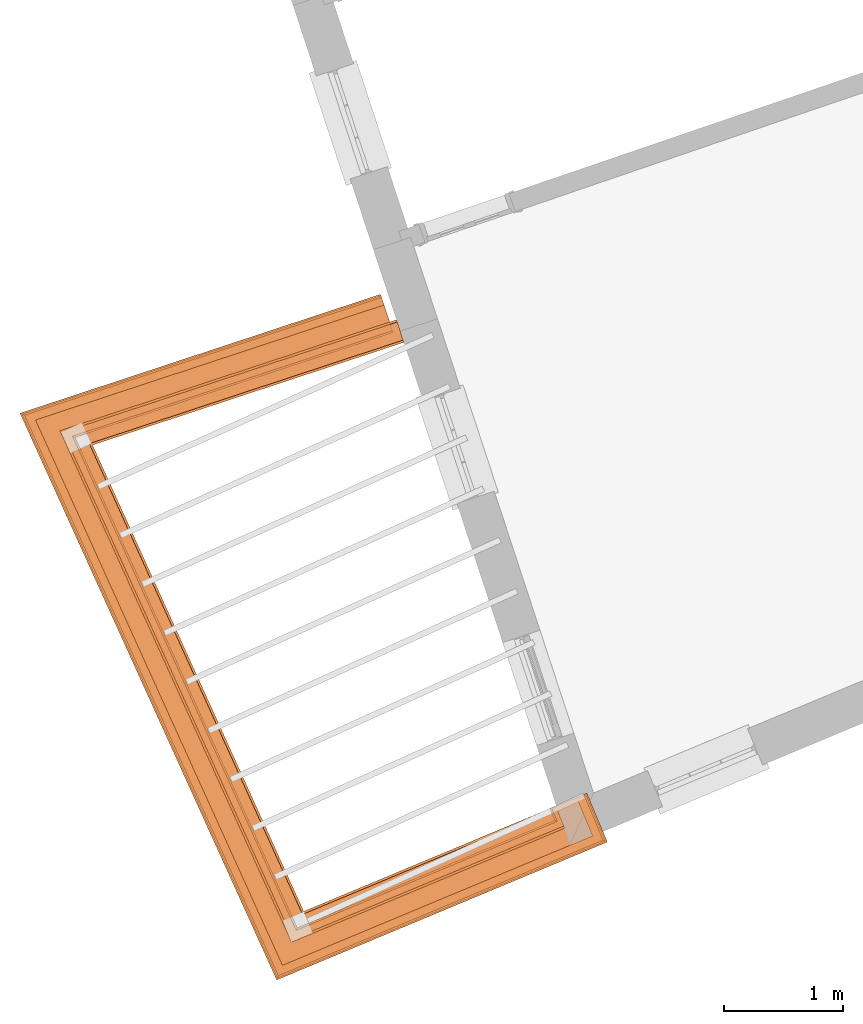
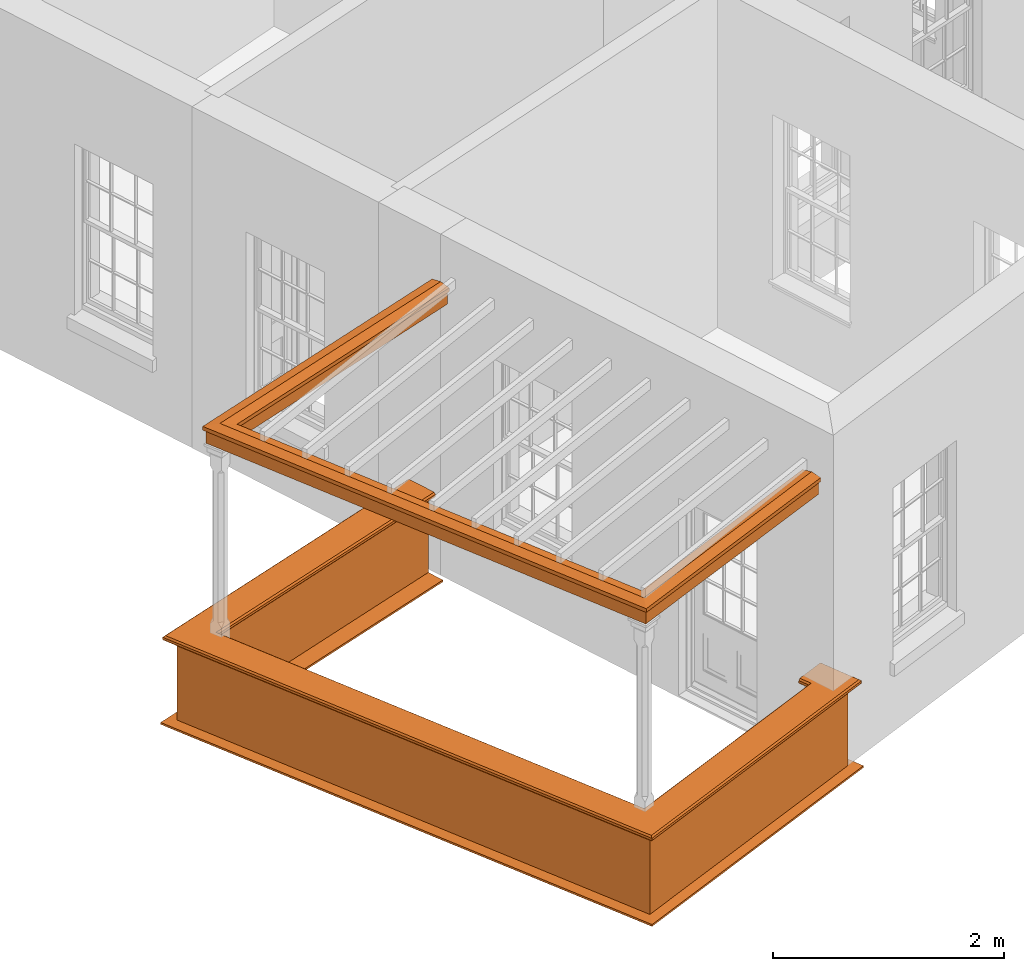
# One storey, part 9 of 10: 5 proxies.
"""IFC2X3 building model written with IfcOpenShell, lengths in metres."""

from ifc_helpers import new_model, entity, si_unit, frame, origin, place, context, subcontext, project, spatial, element, save


model = new_model("IFC2X3")

# Units and contexts
model_context = context("Model", 3, world=origin())
body_context = subcontext(model_context, "Body", "Model", "MODEL_VIEW")
ifc_project = project(units=[si_unit("PLANEANGLEUNIT", "RADIAN"), si_unit("MASSUNIT", "GRAM", prefix="KILO"), si_unit("FORCEUNIT", "NEWTON", prefix="KILO"), si_unit("LENGTHUNIT", "METRE")], contexts=[model_context])

# Site, building, storey
site_placement = place(None, origin())
site = spatial("IfcSite", under=ifc_project, at=site_placement, CompositionType="ELEMENT")
building_placement = place(None, origin())
building = spatial("IfcBuilding", under=site, at=building_placement, Name="Building plot-2", CompositionType="ELEMENT")
storey_placement = place(None, frame((0.0, 0.0, 4.6)))
storey = spatial("IfcBuildingStorey", under=building, at=storey_placement, Name="Floor 1", CompositionType="ELEMENT", Elevation=4.6)

# Proxies
proxy_1_placement = place(storey_placement, origin())
axis2_placement3_d_1 = entity("IfcAxis2Placement3D", entity("IfcCartesianPoint", [0.0, 0.0, 0.0]))
element("IfcBuildingElementProxy", 1, at=proxy_1_placement, inside=storey, Name="parapet", CompositionType="ELEMENT", context=body_context, shape_type="SweptSolid", held_by="IfcProductRepresentation", body=[
    entity("IfcSurfaceCurveSweptAreaSolid", entity("IfcArbitraryClosedProfileDef", "AREA", None, entity("IfcPolyline", [entity("IfcCartesianPoint", [0.0, 0.25]), entity("IfcCartesianPoint", [0.795, 0.25]), entity("IfcCartesianPoint", [0.795, 0.09]), entity("IfcCartesianPoint", [0.02, 0.09]), entity("IfcCartesianPoint", [0.02, -0.08]), entity("IfcCartesianPoint", [0.0, -0.08]), entity("IfcCartesianPoint", [0.0, 0.25])])), axis2_placement3_d_1, entity("IfcPolyline", [entity("IfcCartesianPoint", [29.2960879640093, 30.5431875990457]), entity("IfcCartesianPoint", [26.6320151404297, 29.6644036171361]), entity("IfcCartesianPoint", [28.4917456581951, 25.557898990439]), entity("IfcCartesianPoint", [30.6419656139475, 26.4550986744869]), entity("IfcCartesianPoint", [30.6034574629772, 26.5473869311009])]), 0.0, 1.0, entity("IfcPlane", axis2_placement3_d_1)),
])
proxy_2_placement = place(storey_placement, origin())
axis2_placement3_d_2 = entity("IfcAxis2Placement3D", entity("IfcCartesianPoint", [0.0, 0.0, 0.0]))
element("IfcBuildingElementProxy", 2, at=proxy_2_placement, inside=storey, Name="parapet", CompositionType="ELEMENT", context=body_context, shape_type="SweptSolid", held_by="IfcProductRepresentation", body=[
    entity("IfcSurfaceCurveSweptAreaSolid", entity("IfcArbitraryClosedProfileDef", "AREA", None, entity("IfcPolyline", [entity("IfcCartesianPoint", [0.795, 0.265]), entity("IfcCartesianPoint", [0.807, 0.268]), entity("IfcCartesianPoint", [0.816, 0.274]), entity("IfcCartesianPoint", [0.822, 0.283]), entity("IfcCartesianPoint", [0.825, 0.295]), entity("IfcCartesianPoint", [0.84, 0.295]), entity("IfcCartesianPoint", [0.84, 0.305]), entity("IfcCartesianPoint", [0.842, 0.317]), entity("IfcCartesianPoint", [0.849, 0.326]), entity("IfcCartesianPoint", [0.858, 0.333]), entity("IfcCartesianPoint", [0.87, 0.335]), entity("IfcCartesianPoint", [0.882, 0.333]), entity("IfcCartesianPoint", [0.891, 0.326]), entity("IfcCartesianPoint", [0.898, 0.317]), entity("IfcCartesianPoint", [0.9, 0.305]), entity("IfcCartesianPoint", [0.9, 0.035]), entity("IfcCartesianPoint", [0.898, 0.023]), entity("IfcCartesianPoint", [0.891, 0.014]), entity("IfcCartesianPoint", [0.882, 0.007]), entity("IfcCartesianPoint", [0.87, 0.005]), entity("IfcCartesianPoint", [0.858, 0.007]), entity("IfcCartesianPoint", [0.849, 0.014]), entity("IfcCartesianPoint", [0.842, 0.023]), entity("IfcCartesianPoint", [0.84, 0.035]), entity("IfcCartesianPoint", [0.84, 0.045]), entity("IfcCartesianPoint", [0.825, 0.045]), entity("IfcCartesianPoint", [0.822, 0.057]), entity("IfcCartesianPoint", [0.816, 0.066]), entity("IfcCartesianPoint", [0.807, 0.072]), entity("IfcCartesianPoint", [0.795, 0.075]), entity("IfcCartesianPoint", [0.795, 0.265])])), axis2_placement3_d_2, entity("IfcPolyline", [entity("IfcCartesianPoint", [29.2960879640093, 30.5431875990457]), entity("IfcCartesianPoint", [26.6320151404297, 29.6644036171361]), entity("IfcCartesianPoint", [28.4917456581951, 25.557898990439]), entity("IfcCartesianPoint", [30.6419656139475, 26.4550986744869]), entity("IfcCartesianPoint", [30.6034574629772, 26.5473869311009])]), 0.0, 1.0, entity("IfcPlane", axis2_placement3_d_2)),
])
proxy_3_placement = place(storey_placement, origin())
axis2_placement3_d_3 = entity("IfcAxis2Placement3D", entity("IfcCartesianPoint", [0.0, 0.0, 0.0]))
element("IfcBuildingElementProxy", 3, at=proxy_3_placement, inside=storey, Name="parapet", CompositionType="ELEMENT", context=body_context, shape_type="SweptSolid", held_by="IfcProductRepresentation", body=[
    entity("IfcSurfaceCurveSweptAreaSolid", entity("IfcArbitraryClosedProfileDef", "AREA", None, entity("IfcPolyline", [entity("IfcCartesianPoint", [-0.1, 0.25]), entity("IfcCartesianPoint", [-0.1, 0.265]), entity("IfcCartesianPoint", [-0.085, 0.265]), entity("IfcCartesianPoint", [-0.084, 0.278]), entity("IfcCartesianPoint", [-0.081, 0.289]), entity("IfcCartesianPoint", [-0.074, 0.301]), entity("IfcCartesianPoint", [-0.065, 0.309]), entity("IfcCartesianPoint", [-0.055, 0.315]), entity("IfcCartesianPoint", [-0.044, 0.324]), entity("IfcCartesianPoint", [-0.038, 0.334]), entity("IfcCartesianPoint", [-0.035, 0.345]), entity("IfcCartesianPoint", [-0.015, 0.345]), entity("IfcCartesianPoint", [0.0, 0.25]), entity("IfcCartesianPoint", [-0.1, 0.25])])), axis2_placement3_d_3, entity("IfcPolyline", [entity("IfcCartesianPoint", [29.2960879640093, 30.5431875990457]), entity("IfcCartesianPoint", [26.6320151404297, 29.6644036171361]), entity("IfcCartesianPoint", [28.4917456581951, 25.557898990439]), entity("IfcCartesianPoint", [30.6419656139475, 26.4550986744869]), entity("IfcCartesianPoint", [30.6034574629772, 26.5473869311009])]), 0.0, 1.0, entity("IfcPlane", axis2_placement3_d_3)),
])
proxy_4_placement = place(storey_placement, frame((0.0, 0.0, 3.6)))
axis2_placement3_d_4 = entity("IfcAxis2Placement3D", entity("IfcCartesianPoint", [0.0, 0.0, 0.0]))
element("IfcBuildingElementProxy", 4, at=proxy_4_placement, inside=storey, Name="pergola beam", CompositionType="ELEMENT", context=body_context, shape_type="SweptSolid", held_by="IfcProductRepresentation", body=[
    entity("IfcSurfaceCurveSweptAreaSolid", entity("IfcArbitraryClosedProfileDef", "AREA", None, entity("IfcPolyline", [entity("IfcCartesianPoint", [-0.7, -0.08]), entity("IfcCartesianPoint", [-0.7, 0.08]), entity("IfcCartesianPoint", [-0.56, 0.08]), entity("IfcCartesianPoint", [-0.56, -0.08]), entity("IfcCartesianPoint", [-0.7, -0.08])])), axis2_placement3_d_4, entity("IfcPolyline", [entity("IfcCartesianPoint", [29.3530679742474, 30.5619833015667]), entity("IfcCartesianPoint", [26.6320151404297, 29.6644036171361]), entity("IfcCartesianPoint", [28.4917456581951, 25.557898990439]), entity("IfcCartesianPoint", [30.6973385679159, 26.4782035650691])]), 0.0, 1.0, entity("IfcPlane", axis2_placement3_d_4)),
])
proxy_5_placement = place(storey_placement, frame((0.0, 0.0, 3.6)))
axis2_placement3_d_5 = entity("IfcAxis2Placement3D", entity("IfcCartesianPoint", [0.0, 0.0, 0.0]))
element("IfcBuildingElementProxy", 5, at=proxy_5_placement, inside=storey, Name="pergola beam", CompositionType="ELEMENT", context=body_context, shape_type="SweptSolid", held_by="IfcProductRepresentation", body=[
    entity("IfcSurfaceCurveSweptAreaSolid", entity("IfcArbitraryClosedProfileDef", "AREA", None, entity("IfcPolyline", [entity("IfcCartesianPoint", [-0.5, 0.0]), entity("IfcCartesianPoint", [-0.52, -0.1]), entity("IfcCartesianPoint", [-0.56, -0.1]), entity("IfcCartesianPoint", [-0.56, 0.1]), entity("IfcCartesianPoint", [-0.52, 0.1]), entity("IfcCartesianPoint", [-0.5, 0.0])])), axis2_placement3_d_5, entity("IfcPolyline", [entity("IfcCartesianPoint", [29.3530679742474, 30.5619833015667]), entity("IfcCartesianPoint", [26.6320151404297, 29.6644036171361]), entity("IfcCartesianPoint", [28.4917456581951, 25.557898990439]), entity("IfcCartesianPoint", [30.6973385679159, 26.4782035650691])]), 0.0, 1.0, entity("IfcPlane", axis2_placement3_d_5)),
])

save(model, "model.ifc")
